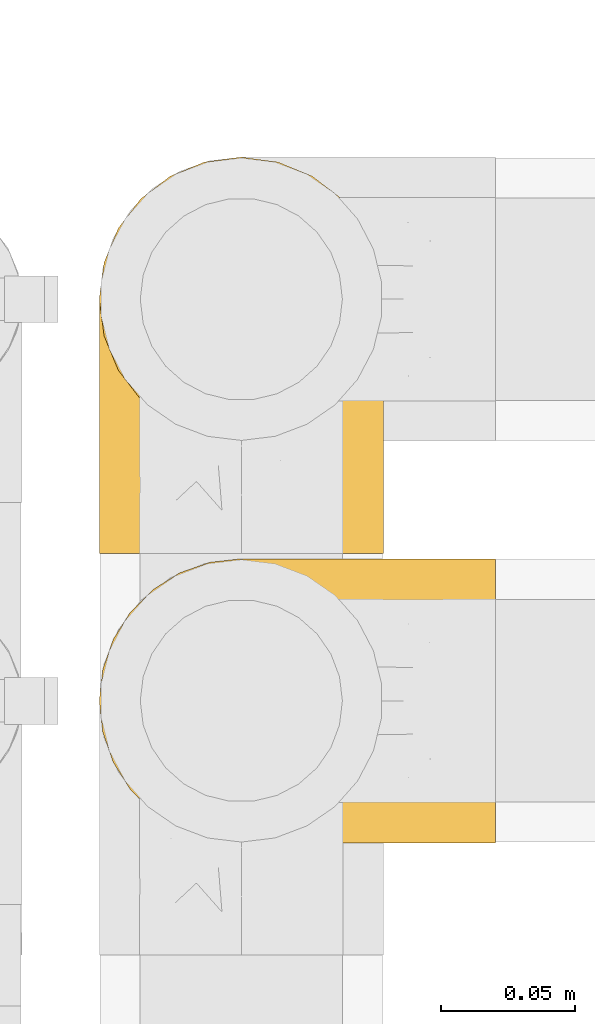
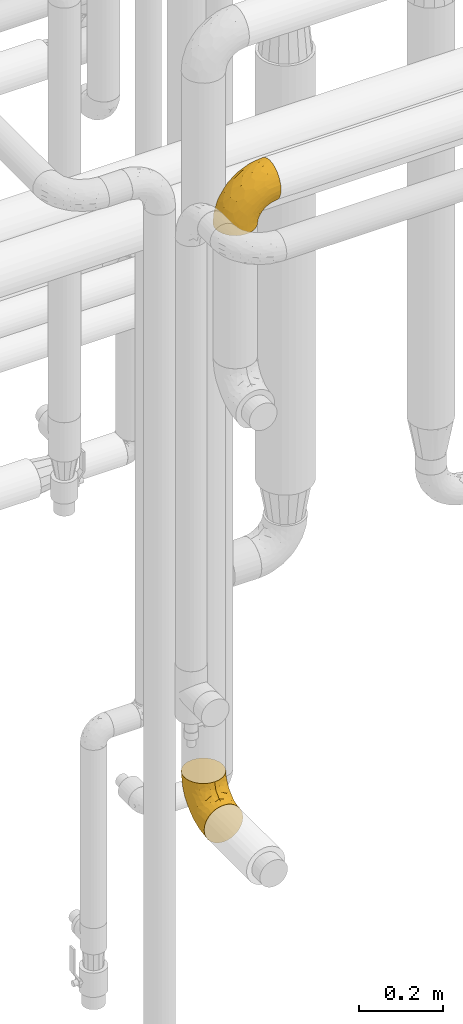
# One storey, part 439 of 827: 2 coverings.
"""IFC2X3 building model written with IfcOpenShell, lengths in millimetres."""

import ifcopenshell
import ifcopenshell.guid

model = None  # the IFC model being written
_history = None  # IfcOwnerHistory: only IFC2X3 demands one
_inside = {}  # id of a spatial element -> (the spatial element, [elements in it])
_under = {}  # id of a project, library or spatial element -> (it, [spatial elements below it])
_declared = {}  # id of a project -> (the project, [libraries it declares])
_typed = {}  # id of a type object -> (the type object, [elements of that type])
_made_of = {}  # id of a material, layer set ... -> (it, [elements and type objects made of it])


def new_model(schema):
    """Start an empty IFC model of exactly this schema.

    Asked for "IFC4X3", IfcOpenShell would pick the latest addendum, in which some entities
    have other attributes; the version numbers below select the first issue.
    IFC2X3 requires an IfcOwnerHistory on every rooted entity: one is made here for all.
    """
    global model, _history
    if schema == "IFC4X3":
        model = ifcopenshell.file(schema_version=(4, 3, 0, 0))
    else:
        model = ifcopenshell.file(schema=schema)
    _inside.clear()
    _under.clear()
    _declared.clear()
    _typed.clear()
    _made_of.clear()
    _history = None
    if model.schema == "IFC2X3":
        org = make("IfcOrganization", Name="unknown")
        user = make(
            "IfcPersonAndOrganization",
            ThePerson=make("IfcPerson", FamilyName="unknown"),
            TheOrganization=org,
        )
        app = make(
            "IfcApplication",
            ApplicationDeveloper=org,
            Version="unknown",
            ApplicationFullName="unknown",
            ApplicationIdentifier="unknown",
        )
        _history = make(
            "IfcOwnerHistory",
            OwningUser=user,
            OwningApplication=app,
            ChangeAction="ADDED",
            CreationDate=0,
        )
    return model


def make(cls, **values):
    """One entity of the class cls with the attributes given. An attribute that is None is left unset."""
    return model.create_entity(
        cls, **{name: value for name, value in values.items() if value is not None}
    )


def entity(cls, *values):
    """Any entity or typed value of the class cls, its attributes in the order of the schema. None: left unset."""
    e = model.create_entity(cls)
    for i, value in enumerate(values):
        if value is not None:
            e[i] = value
    return e


def rooted(cls, **values):
    """An entity with a GlobalId (a new one), such as an element, a storey or a relation."""
    return make(cls, GlobalId=ifcopenshell.guid.new(), OwnerHistory=_history, **values)


def si_unit(unit_type, name, prefix=None):
    """IfcSIUnit, for example si_unit("LENGTHUNIT", "METRE", prefix="MILLI")."""
    return make("IfcSIUnit", UnitType=unit_type, Prefix=prefix, Name=name)


def converted_unit(unit_type, name, factor, base, dimensions=None, offset=None):
    """IfcConversionBasedUnit, such as the inch: factor (a typed value) times the base unit."""
    return make(
        "IfcConversionBasedUnit"
        if offset is None
        else "IfcConversionBasedUnitWithOffset",
        ConversionOffset=offset,
        Dimensions=None
        if dimensions is None
        else entity("IfcDimensionalExponents", *dimensions),
        UnitType=unit_type,
        Name=name,
        ConversionFactor=make(
            "IfcMeasureWithUnit", ValueComponent=factor, UnitComponent=base
        ),
    )


def derived_unit(unit_type, elements):
    """IfcDerivedUnit: a product of units, each with its exponent."""
    return make(
        "IfcDerivedUnit",
        Elements=[
            make("IfcDerivedUnitElement", Unit=unit, Exponent=power)
            for unit, power in elements
        ],
        UnitType=unit_type,
    )


def assignment(units):
    """IfcUnitAssignment: the units of a project."""
    return None if units is None else make("IfcUnitAssignment", Units=units)


def point(xyz):
    """IfcCartesianPoint."""
    return None if xyz is None else make("IfcCartesianPoint", Coordinates=xyz)


def direction(xyz):
    """IfcDirection."""
    return None if xyz is None else make("IfcDirection", DirectionRatios=xyz)


def frame(location, z_axis=None, x_axis=None):
    """IfcAxis2Placement3D, a coordinate frame: its origin and axes. An axis left out is left unset."""
    return make(
        "IfcAxis2Placement3D",
        Location=point(location),
        Axis=direction(z_axis),
        RefDirection=direction(x_axis),
    )


def origin():
    """The frame at (0, 0, 0) with its axes left unset."""
    return frame((0.0, 0.0, 0.0))


def place(relative_to, where):
    """IfcLocalPlacement: puts the frame where relative to a parent placement (None: the world)."""
    return make(
        "IfcLocalPlacement", PlacementRelTo=relative_to, RelativePlacement=where
    )


def context(
    kind, dimensions, precision=None, world=None, true_north=None, identifier=None
):
    """IfcGeometricRepresentationContext, for example the 3D "Model" context."""
    return make(
        "IfcGeometricRepresentationContext",
        ContextIdentifier=identifier,
        ContextType=kind,
        CoordinateSpaceDimension=dimensions,
        Precision=precision,
        WorldCoordinateSystem=world,
        TrueNorth=true_north,
    )


def subcontext(parent, identifier, kind, view, scale=None):
    """IfcGeometricRepresentationSubContext, for example "Body" below "Model"."""
    return make(
        "IfcGeometricRepresentationSubContext",
        ContextIdentifier=identifier,
        ContextType=kind,
        ParentContext=parent,
        TargetScale=scale,
        TargetView=view,
    )


def project(units=None, contexts=None):
    """IfcProject with its units and contexts."""
    return rooted(
        "IfcProject",
        Name="project",
        RepresentationContexts=contexts,
        UnitsInContext=assignment(units),
    )


def spatial(cls, under=None, at=None, **own):
    """A site, building, storey or space (cls), placed at a placement, below another one or the project."""
    s = rooted(cls, ObjectPlacement=at, **own)
    if under is not None:
        _under.setdefault(under.id(), (under, []))[1].append(s)
    return s


def faces_of(points, faces, orient=None, outer=None):
    """IfcFace entities. A face is a list of loops; a loop is a list of indices into points, from 0.

    orient and outer hold one flag for each loop. By default every Orientation is true, the
    first loop of a face is its IfcFaceOuterBound and the others are IfcFaceBound.
    """
    made = []
    for i, loops in enumerate(faces):
        bounds = []
        for j, loop in enumerate(loops):
            is_outer = j == 0 if outer is None else outer[i][j]
            bounds.append(
                make(
                    "IfcFaceOuterBound" if is_outer else "IfcFaceBound",
                    Bound=make("IfcPolyLoop", Polygon=[points[k] for k in loop]),
                    Orientation=True if orient is None else orient[i][j],
                )
            )
        made.append(make("IfcFace", Bounds=bounds))
    return made


def faceted_brep(points, faces, orient=None, outer=None, voids=None):
    """IfcFacetedBrep: a solid bounded by flat faces; with voids (closed shells), ...WithVoids."""
    shared = [point(p) for p in points]
    hull = make("IfcClosedShell", CfsFaces=faces_of(shared, faces, orient, outer))
    if voids is None:
        return make("IfcFacetedBrep", Outer=hull)
    return make(
        "IfcFacetedBrepWithVoids",
        Outer=hull,
        Voids=[
            make(cls, CfsFaces=faces_of(shared, fs, o, b)) for cls, fs, o, b in voids
        ],
    )


def shape(context_of_items, identifier, shape_type, items):
    """IfcShapeRepresentation: the items that make up one representation, for example the "Body"."""
    return make(
        "IfcShapeRepresentation",
        ContextOfItems=context_of_items,
        RepresentationIdentifier=identifier,
        RepresentationType=shape_type,
        Items=items,
    )


def made_of(thing, what):
    """Note that an element or type object is made of a material, layer set ...; save() writes the relation."""
    if what is not None:
        _made_of.setdefault(what.id(), (what, []))[1].append(thing)
    return thing


def element(
    cls,
    number,
    at=None,
    inside=None,
    cuts=None,
    type_object=None,
    material=None,
    context=None,
    identifier="Body",
    shape_type=None,
    held_by="IfcProductDefinitionShape",
    body=None,
    shapes=None,
    **own,
):
    """One element of the class cls, such as IfcWall. Its Tag is "e" and its number.

    at: its placement. inside: the storey or other place that contains it. cuts: it is an
    opening in that element (IfcRelVoidsElement). A single representation is given by context,
    identifier, shape_type and body (its items); several are given by shapes. held_by: the class
    of the entity that holds the representations. save() writes the other relations.
    """
    e = rooted(cls, Tag="e%d" % number, ObjectPlacement=at, **own)
    if body is not None:
        shapes = [shape(context, identifier, shape_type, body)]
    if shapes is not None:
        e.Representation = make(held_by, Representations=shapes)
    if inside is not None:
        _inside.setdefault(inside.id(), (inside, []))[1].append(e)
    if cuts is not None:
        rooted(
            "IfcRelVoidsElement", RelatingBuildingElement=cuts, RelatedOpeningElement=e
        )
    if type_object is not None:
        _typed.setdefault(type_object.id(), (type_object, []))[1].append(e)
    return made_of(e, material)


def aggregate(whole, parts):
    """IfcRelAggregates: a whole, such as a stair, and the parts it consists of."""
    return rooted("IfcRelAggregates", RelatingObject=whole, RelatedObjects=parts)


def save(model, path):
    """Write the relations noted so far, then the file.

    IfcRelAggregates (storeys below a building ...), IfcRelContainedInSpatialStructure (elements
    in a storey), IfcRelDefinesByType, IfcRelAssociatesMaterial and IfcRelDeclares: one each for
    every whole, place, type object, material and project.
    """
    for whole, parts in _under.values():
        aggregate(whole, parts)
    for where, things in _inside.values():
        rooted(
            "IfcRelContainedInSpatialStructure",
            RelatedElements=things,
            RelatingStructure=where,
        )
    for kind, things in _typed.values():
        rooted("IfcRelDefinesByType", RelatedObjects=things, RelatingType=kind)
    for what, things in _made_of.values():
        rooted("IfcRelAssociatesMaterial", RelatedObjects=things, RelatingMaterial=what)
    for by, libraries in _declared.values():
        rooted("IfcRelDeclares", RelatingContext=by, RelatedDefinitions=libraries)
    model.write(path)


model = new_model("IFC2X3")

# Units and contexts
model_context = context("Model", 3, precision=0.01, world=origin(), true_north=direction((6.12303176911189e-17, 1.0)))
body_context = subcontext(model_context, "Body", "Model", "MODEL_VIEW")
ifc_project = project(units=[si_unit("LENGTHUNIT", "METRE", prefix="MILLI"), si_unit("AREAUNIT", "SQUARE_METRE"), si_unit("VOLUMEUNIT", "CUBIC_METRE"), converted_unit("PLANEANGLEUNIT", "DEGREE", entity("IfcRatioMeasure", 0.0174532925199433), si_unit("PLANEANGLEUNIT", "RADIAN"), dimensions=[0, 0, 0, 0, 0, 0, 0]), si_unit("MASSUNIT", "GRAM", prefix="KILO"), derived_unit("MASSDENSITYUNIT", [(si_unit("MASSUNIT", "GRAM", prefix="KILO"), 1), (si_unit("LENGTHUNIT", "METRE"), -3)]), derived_unit("MOMENTOFINERTIAUNIT", [(si_unit("LENGTHUNIT", "METRE"), 4)]), si_unit("TIMEUNIT", "SECOND"), si_unit("FREQUENCYUNIT", "HERTZ"), si_unit("THERMODYNAMICTEMPERATUREUNIT", "DEGREE_CELSIUS"), derived_unit("THERMALTRANSMITTANCEUNIT", [(si_unit("MASSUNIT", "GRAM", prefix="KILO"), 1), (si_unit("THERMODYNAMICTEMPERATUREUNIT", "KELVIN"), -1), (si_unit("TIMEUNIT", "SECOND"), -3)]), derived_unit("VOLUMETRICFLOWRATEUNIT", [(si_unit("LENGTHUNIT", "METRE"), 3), (si_unit("TIMEUNIT", "SECOND"), -1)]), derived_unit("MASSFLOWRATEUNIT", [(si_unit("MASSUNIT", "GRAM", prefix="KILO"), 1), (si_unit("TIMEUNIT", "SECOND"), -1)]), derived_unit("ROTATIONALFREQUENCYUNIT", [(si_unit("TIMEUNIT", "SECOND"), -1)]), si_unit("ELECTRICCURRENTUNIT", "AMPERE"), si_unit("ELECTRICVOLTAGEUNIT", "VOLT"), si_unit("POWERUNIT", "WATT"), si_unit("FORCEUNIT", "NEWTON", prefix="KILO"), si_unit("ILLUMINANCEUNIT", "LUX"), si_unit("LUMINOUSFLUXUNIT", "LUMEN"), si_unit("LUMINOUSINTENSITYUNIT", "CANDELA"), derived_unit("USERDEFINED", [(si_unit("MASSUNIT", "GRAM", prefix="KILO"), -1), (si_unit("LENGTHUNIT", "METRE"), -2), (si_unit("TIMEUNIT", "SECOND"), 3), (si_unit("LUMINOUSFLUXUNIT", "LUMEN"), 1)]), derived_unit("LINEARVELOCITYUNIT", [(si_unit("LENGTHUNIT", "METRE"), 1), (si_unit("TIMEUNIT", "SECOND"), -1)]), si_unit("PRESSUREUNIT", "PASCAL"), derived_unit("USERDEFINED", [(si_unit("LENGTHUNIT", "METRE"), -2), (si_unit("MASSUNIT", "GRAM", prefix="KILO"), 1), (si_unit("TIMEUNIT", "SECOND"), -2)]), derived_unit("LINEARFORCEUNIT", [(si_unit("MASSUNIT", "GRAM", prefix="KILO"), 1), (si_unit("LENGTHUNIT", "METRE"), 1), (si_unit("TIMEUNIT", "SECOND"), -2), (si_unit("LENGTHUNIT", "METRE"), -1)]), derived_unit("PLANARFORCEUNIT", [(si_unit("MASSUNIT", "GRAM", prefix="KILO"), 1), (si_unit("LENGTHUNIT", "METRE"), 1), (si_unit("TIMEUNIT", "SECOND"), -2), (si_unit("LENGTHUNIT", "METRE"), -2)])], contexts=[model_context])

# Site, building, storey
site_placement = place(None, origin())
site = spatial("IfcSite", under=ifc_project, at=site_placement, CompositionType="ELEMENT")
building_placement = place(site_placement, origin())
building = spatial("IfcBuilding", under=site, at=building_placement, CompositionType="ELEMENT")
storey_placement = place(building_placement, frame((0.0, 0.0, 28200.0)))
storey = spatial("IfcBuildingStorey", under=building, at=storey_placement, Name="08", CompositionType="ELEMENT", Elevation=28200.0)

# Coverings
covering_1_placement = place(storey_placement, frame((55701.2, 15549.61, 1130.35)))
element("IfcCovering", 1, at=covering_1_placement, inside=storey, Name=":ADSK_", ObjectType=":ADSK_", PredefinedType="INSULATION", context=body_context, shape_type="Brep", body=[
    faceted_brep([(42.85, 1.6, 2.92), (54.65, 1.6, 1.6), (66.46, 1.6, 2.93), (77.67, 1.6, 6.85), (87.73, 1.6, 13.18), (96.13, 1.6, 21.58), (102.45, 1.6, 31.64), (106.37, 1.6, 42.85), (107.7, 1.6, 54.65), (106.36, 1.6, 66.46), (102.44, 1.6, 77.67), (96.11, 1.6, 87.73), (87.71, 1.6, 96.13), (77.65, 1.6, 102.45), (66.44, 1.6, 106.37), (54.65, 1.6, 107.7), (42.84, 1.6, 106.36), (31.62, 1.6, 102.44), (21.56, 1.6, 96.11), (13.16, 1.6, 87.71), (6.84, 1.6, 77.65), (2.92, 1.6, 66.44), (1.6, 1.6, 54.65), (2.93, 1.6, 42.84), (6.85, 1.6, 31.62), (13.18, 1.6, 21.56), (21.58, 1.6, 13.16), (31.64, 1.6, 6.84), (68.38, 45.35, 149.65), (81.17, 50.65, 149.65), (92.16, 59.08, 149.65), (100.59, 70.07, 149.65), (105.89, 82.86, 149.65), (107.7, 96.6, 149.65), (105.89, 110.33, 149.65), (100.59, 123.12, 149.65), (92.16, 134.11, 149.65), (81.17, 142.54, 149.65), (68.38, 147.84, 149.65), (54.65, 149.65, 149.65), (40.91, 147.84, 149.65), (28.12, 142.54, 149.65), (17.13, 134.11, 149.65), (8.7, 123.12, 149.65), (3.4, 110.33, 149.65), (1.6, 96.6, 149.65), (3.4, 82.86, 149.65), (8.7, 70.07, 149.65), (17.13, 59.08, 149.65), (28.12, 50.65, 149.65), (40.91, 45.35, 149.65), (54.65, 43.55, 149.65), (23.76, 137.19, 123.27), (35.87, 141.79, 114.15), (25.52, 128.89, 92.97), (45.07, 146.54, 124.11), (54.65, 144.6, 111.33), (12.57, 69.77, 42.13), (15.93, 94.41, 56.83), (24.82, 87.22, 40.31), (37.92, 117.2, 61.55), (54.65, 129.81, 75.62), (54.65, 106.28, 44.96), (5.82, 101.45, 91.12), (8.38, 115.81, 109.83), (10.19, 109.14, 88.02), (3.86, 107.65, 119.19), (2.5, 93.36, 99.11), (19.48, 59.44, 27.97), (29.7, 63.23, 21.92), (28.0, 35.59, 12.94), (35.28, 132.3, 88.29), (45.15, 138.41, 95.35), (14.54, 126.28, 113.84), (54.65, 39.91, 6.64), (38.55, 37.44, 8.58), (40.99, 90.35, 33.39), (43.24, 65.0, 17.23), (8.56, 85.4, 61.99), (2.51, 26.66, 47.9), (5.69, 29.88, 37.72), (1.6, 78.45, 93.81), (1.6, 85.2, 107.05), (1.6, 91.95, 120.29), (3.22, 77.98, 73.26), (18.7, 29.55, 18.58), (11.86, 41.42, 29.72), (24.78, 111.13, 64.31), (15.99, 114.67, 82.84), (1.6, 57.43, 72.79), (1.6, 67.94, 83.3), (1.6, 14.64, 56.71), (1.6, 30.95, 59.29), (2.5, 52.13, 57.88), (1.6, 44.19, 66.04), (5.82, 60.12, 49.8), (54.65, 75.62, 21.43), (1.6, 94.27, 134.97), (32.3, 24.59, 108.79), (25.01, 34.69, 110.84), (18.18, 31.15, 101.53), (3.03, 75.18, 111.84), (6.69, 67.55, 119.98), (3.21, 79.36, 123.54), (2.73, 84.32, 134.54), (3.93, 40.81, 80.57), (2.55, 29.93, 69.55), (7.7, 70.24, 134.56), (54.65, 37.93, 128.67), (54.65, 40.15, 136.98), (41.58, 42.1, 133.56), (17.93, 55.38, 131.66), (14.97, 52.17, 117.75), (22.2, 44.32, 118.23), (43.45, 19.85, 110.55), (54.65, 14.26, 111.09), (54.65, 22.57, 113.32), (40.37, 34.17, 120.2), (8.47, 54.85, 105.95), (29.46, 44.63, 127.69), (32.17, 47.52, 139.88), (3.39, 59.1, 92.14), (7.76, 44.11, 93.82), (2.57, 53.21, 82.28), (11.54, 62.86, 130.86), (6.21, 20.58, 78.78), (2.9, 15.79, 67.58), (11.19, 27.67, 90.58), (14.27, 13.49, 90.23), (22.4, 18.04, 99.39), (34.87, 12.44, 105.17), (54.65, 30.25, 120.99), (4.01, 66.71, 104.59), (16.42, 42.52, 108.24), (91.36, 55.38, 131.66), (103.07, 20.57, 78.8), (67.71, 42.11, 133.57), (107.7, 57.43, 72.79), (106.72, 53.22, 82.27), (105.35, 40.81, 80.59), (65.83, 19.85, 110.55), (76.97, 24.58, 108.79), (68.91, 34.16, 120.2), (92.85, 42.5, 108.25), (100.82, 54.93, 106.06), (94.28, 52.13, 117.78), (98.08, 27.66, 90.6), (101.51, 44.12, 93.87), (107.7, 78.45, 93.81), (107.7, 85.2, 107.05), (106.25, 75.17, 111.89), (107.7, 94.27, 134.97), (106.56, 84.32, 134.54), (107.7, 30.95, 59.29), (107.7, 44.19, 66.04), (106.74, 29.98, 69.56), (105.31, 66.78, 104.56), (102.6, 67.55, 119.98), (101.59, 70.24, 134.56), (106.08, 79.36, 123.54), (95.01, 13.48, 90.25), (86.87, 18.03, 99.4), (84.27, 34.66, 110.83), (91.11, 31.14, 101.52), (74.4, 12.43, 105.18), (107.7, 14.64, 56.71), (77.12, 47.52, 139.89), (87.06, 44.28, 118.22), (106.38, 15.8, 67.6), (97.75, 62.86, 130.86), (107.7, 67.94, 83.3), (79.83, 44.64, 127.71), (105.91, 59.12, 92.12), (107.7, 91.95, 120.29), (83.77, 128.89, 92.97), (85.53, 137.19, 123.27), (94.75, 126.28, 113.84), (100.91, 115.81, 109.83), (64.22, 146.53, 124.03), (73.42, 141.79, 114.15), (64.15, 139.45, 98.04), (106.79, 93.36, 99.11), (106.79, 26.67, 47.9), (103.61, 29.87, 37.74), (103.47, 60.12, 49.8), (93.36, 94.41, 56.83), (96.75, 69.76, 42.16), (84.48, 87.19, 40.3), (106.79, 52.13, 57.88), (106.07, 77.98, 73.26), (105.43, 107.65, 119.19), (73.44, 131.74, 86.61), (89.82, 59.44, 27.99), (90.61, 29.54, 18.59), (79.61, 63.2, 21.92), (81.34, 27.9, 11.28), (68.3, 90.35, 33.39), (71.37, 117.2, 61.55), (97.44, 41.39, 29.73), (99.1, 109.14, 88.01), (100.74, 85.46, 62.08), (70.76, 37.43, 8.58), (93.3, 114.67, 82.84), (84.5, 111.12, 64.3), (103.47, 101.45, 91.12), (68.73, 65.16, 18.05)], [[[0, 1, 2, 3, 4, 5, 6, 7, 8, 9, 10, 11, 12, 13, 14, 15, 16, 17, 18, 19, 20, 21, 22, 23, 24, 25, 26, 27]], [[28, 29, 30, 31, 32, 33, 34, 35, 36, 37, 38, 39, 40, 41, 42, 43, 44, 45, 46, 47, 48, 49, 50, 51]], [[52, 53, 54]], [[55, 39, 56]], [[57, 58, 59]], [[60, 61, 62]], [[63, 64, 65]], [[66, 63, 67]], [[68, 69, 70]], [[53, 71, 54]], [[41, 40, 53]], [[53, 72, 71]], [[73, 42, 52]], [[42, 41, 52]], [[74, 0, 75]], [[69, 76, 77]], [[43, 73, 64]], [[45, 44, 66]], [[57, 78, 58]], [[23, 79, 80]], [[67, 81, 82, 83]], [[67, 84, 81]], [[24, 23, 80]], [[25, 85, 26]], [[86, 85, 25]], [[42, 73, 43]], [[0, 27, 75]], [[25, 24, 86]], [[70, 26, 85]], [[0, 74, 1]], [[68, 85, 86]], [[66, 64, 63]], [[60, 59, 87]], [[54, 87, 88]], [[76, 60, 62]], [[84, 89, 90, 81]], [[79, 22, 91, 92]], [[77, 74, 75]], [[93, 92, 94, 89]], [[80, 86, 24]], [[40, 55, 53]], [[76, 59, 60]], [[93, 84, 95]], [[76, 62, 96]], [[55, 72, 53]], [[70, 27, 26]], [[75, 70, 69]], [[78, 84, 63]], [[93, 79, 92]], [[95, 86, 80]], [[77, 76, 96]], [[59, 69, 68]], [[57, 68, 86]], [[68, 57, 59]], [[59, 58, 87]], [[76, 69, 59]], [[88, 87, 58]], [[87, 54, 71]], [[86, 95, 57]], [[78, 57, 95]], [[84, 78, 95]], [[78, 63, 65]], [[58, 78, 65]], [[54, 88, 73]], [[84, 93, 89]], [[79, 95, 80]], [[79, 93, 95]], [[22, 79, 23]], [[66, 83, 97, 45]], [[84, 67, 63]], [[83, 66, 67]], [[64, 44, 43]], [[64, 66, 44]], [[65, 73, 88]], [[53, 52, 41]], [[73, 52, 54]], [[73, 65, 64]], [[65, 88, 58]], [[39, 55, 40]], [[72, 55, 56]], [[56, 61, 72]], [[60, 72, 61]], [[72, 60, 71]], [[87, 71, 60]], [[27, 70, 75]], [[68, 70, 85]], [[74, 77, 96]], [[69, 77, 75]], [[98, 99, 100]], [[46, 45, 97]], [[101, 102, 103]], [[103, 104, 83]], [[105, 94, 106]], [[107, 103, 102]], [[108, 109, 51, 110]], [[111, 112, 113]], [[114, 115, 116]], [[47, 104, 107]], [[110, 117, 108]], [[49, 48, 111]], [[102, 118, 112]], [[119, 120, 111]], [[50, 49, 120]], [[121, 122, 118]], [[105, 123, 89]], [[124, 48, 107]], [[20, 19, 125]], [[121, 81, 90]], [[117, 119, 99]], [[21, 20, 126]], [[22, 21, 91]], [[105, 125, 127]], [[110, 51, 50]], [[19, 128, 125]], [[16, 15, 115]], [[129, 98, 100]], [[126, 91, 21]], [[128, 129, 127]], [[122, 123, 105]], [[114, 117, 98]], [[17, 16, 130]], [[18, 128, 19]], [[129, 18, 17]], [[125, 106, 126]], [[115, 114, 16]], [[130, 129, 17]], [[114, 98, 130]], [[117, 116, 131, 108]], [[99, 119, 113]], [[122, 121, 123]], [[92, 126, 106]], [[105, 127, 122]], [[132, 121, 118]], [[114, 130, 16]], [[129, 130, 98]], [[50, 120, 110]], [[129, 128, 18]], [[125, 128, 127]], [[125, 126, 20]], [[91, 126, 92]], [[105, 89, 94]], [[105, 106, 125]], [[94, 92, 106]], [[100, 122, 127]], [[118, 122, 133]], [[112, 118, 133]], [[132, 118, 102]], [[132, 102, 101]], [[81, 121, 132]], [[82, 103, 83]], [[132, 101, 81]], [[104, 47, 46]], [[124, 107, 102]], [[48, 47, 107]], [[113, 112, 133]], [[112, 111, 124]], [[99, 113, 133]], [[111, 113, 119]], [[99, 133, 100]], [[117, 99, 98]], [[122, 100, 133]], [[127, 129, 100]], [[103, 82, 101]], [[81, 101, 82]], [[112, 124, 102]], [[48, 124, 111]], [[104, 103, 107]], [[46, 97, 104]], [[111, 120, 49]], [[83, 104, 97]], [[110, 120, 119]], [[117, 110, 119]], [[116, 117, 114]], [[89, 123, 90]], [[90, 123, 121]], [[30, 29, 134]], [[11, 10, 135]], [[51, 109, 108, 136]], [[137, 138, 139]], [[140, 141, 142]], [[143, 144, 145]], [[146, 139, 147]], [[148, 149, 150]], [[151, 32, 152]], [[153, 154, 155]], [[156, 150, 157]], [[158, 157, 159]], [[108, 142, 136]], [[31, 158, 152]], [[160, 161, 12]], [[162, 163, 143]], [[140, 142, 116]], [[142, 141, 162]], [[14, 164, 140]], [[14, 140, 115]], [[9, 8, 165]], [[160, 12, 11]], [[141, 164, 161]], [[13, 12, 161]], [[14, 115, 15]], [[28, 166, 29]], [[135, 139, 146]], [[141, 163, 162]], [[135, 146, 160]], [[143, 167, 162]], [[29, 166, 134]], [[116, 142, 108, 131]], [[165, 153, 168]], [[10, 9, 168]], [[168, 135, 10]], [[138, 147, 139]], [[158, 169, 157]], [[14, 13, 164]], [[116, 115, 140]], [[145, 167, 143]], [[135, 160, 11]], [[168, 153, 155]], [[138, 137, 170]], [[157, 144, 156]], [[147, 144, 143]], [[161, 164, 13]], [[140, 164, 141]], [[142, 171, 136]], [[136, 171, 166]], [[161, 160, 146]], [[165, 168, 9]], [[155, 139, 135]], [[139, 154, 137]], [[168, 155, 135]], [[139, 155, 154]], [[144, 147, 172]], [[163, 147, 143]], [[156, 144, 172]], [[157, 169, 145]], [[172, 148, 156]], [[173, 159, 149]], [[159, 157, 150]], [[152, 159, 173]], [[159, 152, 158]], [[31, 30, 158]], [[169, 30, 134]], [[157, 145, 144]], [[167, 134, 171]], [[134, 167, 145]], [[171, 142, 162]], [[162, 167, 171]], [[163, 141, 161]], [[161, 146, 163]], [[147, 163, 146]], [[148, 150, 156]], [[149, 159, 150]], [[30, 169, 158]], [[145, 169, 134]], [[151, 33, 32]], [[31, 152, 32]], [[152, 173, 151]], [[28, 51, 136]], [[134, 166, 171]], [[28, 136, 166]], [[138, 170, 172]], [[147, 138, 172]], [[148, 172, 170]], [[174, 175, 176]], [[35, 34, 177]], [[178, 179, 180]], [[181, 173, 149, 148]], [[182, 183, 184]], [[185, 186, 187]], [[188, 189, 137]], [[190, 33, 151, 173]], [[191, 179, 174]], [[34, 190, 177]], [[39, 38, 178]], [[192, 193, 194]], [[4, 3, 195]], [[175, 179, 37]], [[38, 37, 179]], [[35, 176, 36]], [[196, 62, 197]], [[181, 190, 173]], [[37, 36, 175]], [[183, 6, 198]], [[189, 148, 170, 137]], [[185, 199, 200]], [[3, 2, 201]], [[202, 185, 203]], [[8, 7, 182]], [[200, 184, 186]], [[183, 7, 6]], [[181, 189, 204]], [[200, 189, 184]], [[5, 198, 6]], [[187, 203, 185]], [[195, 3, 201]], [[205, 196, 194]], [[62, 61, 197]], [[186, 198, 192]], [[180, 179, 191]], [[2, 1, 74]], [[198, 193, 192]], [[193, 5, 4]], [[194, 193, 195]], [[2, 74, 201]], [[5, 193, 198]], [[205, 74, 96]], [[188, 137, 154, 153]], [[62, 196, 96]], [[56, 178, 180]], [[198, 184, 183]], [[184, 188, 182]], [[203, 197, 191]], [[205, 194, 201]], [[187, 192, 194]], [[192, 187, 186]], [[194, 196, 187]], [[197, 187, 196]], [[197, 203, 187]], [[202, 174, 176]], [[200, 186, 185]], [[184, 198, 186]], [[199, 185, 202]], [[189, 200, 204]], [[174, 202, 203]], [[176, 177, 199]], [[189, 181, 148]], [[190, 181, 204]], [[190, 204, 177]], [[190, 34, 33]], [[188, 153, 182]], [[189, 188, 184]], [[182, 153, 165, 8]], [[183, 182, 7]], [[199, 177, 204]], [[35, 177, 176]], [[176, 175, 36]], [[179, 175, 174]], [[200, 199, 204]], [[176, 199, 202]], [[203, 191, 174]], [[180, 197, 61]], [[197, 180, 191]], [[61, 56, 180]], [[39, 178, 56]], [[38, 179, 178]], [[194, 195, 201]], [[4, 195, 193]], [[74, 205, 201]], [[96, 196, 205]]]),
])
covering_2_placement = place(storey_placement, frame((55701.2, 15441.56, 2953.4)))
element("IfcCovering", 2, at=covering_2_placement, inside=storey, Name=":ADSK_", ObjectType=":ADSK_", PredefinedType="INSULATION", context=body_context, shape_type="Brep", body=[
    faceted_brep([(2.92, 42.85, 1.6), (1.6, 54.65, 1.6), (2.93, 66.46, 1.6), (6.85, 77.67, 1.6), (13.18, 87.73, 1.6), (21.58, 96.13, 1.6), (31.64, 102.45, 1.6), (42.85, 106.37, 1.6), (54.65, 107.7, 1.6), (66.46, 106.36, 1.6), (77.67, 102.44, 1.6), (87.73, 96.11, 1.6), (96.13, 87.71, 1.6), (102.45, 77.65, 1.6), (106.37, 66.44, 1.6), (107.7, 54.65, 1.6), (106.36, 42.84, 1.6), (102.44, 31.62, 1.6), (96.11, 21.56, 1.6), (87.71, 13.16, 1.6), (77.65, 6.84, 1.6), (66.44, 2.92, 1.6), (54.65, 1.6, 1.6), (42.84, 2.93, 1.6), (31.62, 6.85, 1.6), (21.56, 13.18, 1.6), (13.16, 21.58, 1.6), (6.84, 31.64, 1.6), (149.65, 68.38, 45.35), (149.65, 81.17, 50.65), (149.65, 92.16, 59.08), (149.65, 100.59, 70.07), (149.65, 105.89, 82.86), (149.65, 107.7, 96.6), (149.65, 105.89, 110.33), (149.65, 100.59, 123.12), (149.65, 92.16, 134.11), (149.65, 81.17, 142.54), (149.65, 68.38, 147.84), (149.65, 54.65, 149.65), (149.65, 40.91, 147.84), (149.65, 28.12, 142.54), (149.65, 17.13, 134.11), (149.65, 8.7, 123.12), (149.65, 3.4, 110.33), (149.65, 1.6, 96.6), (149.65, 3.4, 82.86), (149.65, 8.7, 70.07), (149.65, 17.13, 59.08), (149.65, 28.12, 50.65), (149.65, 40.91, 45.35), (149.65, 54.65, 43.55), (123.27, 23.76, 137.19), (114.15, 35.87, 141.79), (92.97, 25.52, 128.89), (124.11, 45.07, 146.54), (111.33, 54.65, 144.6), (42.13, 12.57, 69.77), (56.83, 15.93, 94.41), (40.31, 24.82, 87.22), (61.55, 37.92, 117.2), (75.62, 54.65, 129.81), (44.96, 54.65, 106.28), (91.12, 5.82, 101.45), (109.83, 8.38, 115.81), (88.02, 10.19, 109.14), (119.19, 3.86, 107.65), (99.11, 2.5, 93.36), (27.97, 19.48, 59.44), (21.92, 29.7, 63.23), (12.94, 28.0, 35.59), (88.29, 35.28, 132.3), (95.35, 45.15, 138.41), (113.84, 14.54, 126.28), (6.64, 54.65, 39.91), (8.58, 38.55, 37.44), (33.39, 40.99, 90.35), (17.23, 43.24, 65.0), (61.99, 8.56, 85.4), (47.9, 2.51, 26.66), (37.72, 5.69, 29.88), (93.81, 1.6, 78.45), (107.05, 1.6, 85.2), (120.29, 1.6, 91.95), (73.26, 3.22, 77.98), (18.58, 18.7, 29.55), (29.72, 11.86, 41.42), (64.31, 24.78, 111.13), (82.84, 15.99, 114.67), (72.79, 1.6, 57.43), (83.3, 1.6, 67.94), (56.71, 1.6, 14.64), (59.29, 1.6, 30.95), (57.88, 2.5, 52.13), (66.04, 1.6, 44.19), (49.8, 5.82, 60.12), (21.43, 54.65, 75.62), (134.97, 1.6, 94.27), (108.79, 32.3, 24.59), (110.84, 25.01, 34.69), (101.53, 18.18, 31.15), (111.84, 3.03, 75.18), (119.98, 6.69, 67.55), (123.54, 3.21, 79.36), (134.54, 2.73, 84.32), (80.57, 3.93, 40.81), (69.55, 2.55, 29.93), (134.56, 7.7, 70.24), (128.67, 54.65, 37.93), (136.98, 54.65, 40.15), (133.56, 41.58, 42.1), (131.66, 17.93, 55.38), (117.75, 14.97, 52.17), (118.23, 22.2, 44.32), (110.55, 43.45, 19.85), (111.09, 54.65, 14.26), (113.32, 54.65, 22.57), (120.2, 40.37, 34.17), (105.95, 8.47, 54.85), (127.69, 29.46, 44.63), (139.88, 32.17, 47.52), (92.14, 3.39, 59.1), (93.82, 7.76, 44.11), (82.28, 2.57, 53.21), (130.86, 11.54, 62.86), (78.78, 6.21, 20.58), (67.58, 2.9, 15.79), (90.58, 11.19, 27.67), (90.23, 14.27, 13.49), (99.39, 22.4, 18.04), (105.17, 34.87, 12.44), (120.99, 54.65, 30.25), (104.59, 4.01, 66.71), (108.24, 16.42, 42.52), (131.66, 91.36, 55.38), (78.8, 103.07, 20.57), (133.57, 67.71, 42.11), (72.79, 107.7, 57.43), (82.27, 106.72, 53.22), (80.59, 105.35, 40.81), (110.55, 65.83, 19.85), (108.79, 76.97, 24.58), (120.2, 68.91, 34.16), (108.25, 92.85, 42.5), (106.06, 100.82, 54.93), (117.78, 94.28, 52.13), (90.6, 98.08, 27.66), (93.87, 101.51, 44.12), (93.81, 107.7, 78.45), (107.05, 107.7, 85.2), (111.89, 106.25, 75.17), (134.97, 107.7, 94.27), (134.54, 106.56, 84.32), (59.29, 107.7, 30.95), (66.04, 107.7, 44.19), (69.56, 106.74, 29.98), (104.56, 105.31, 66.78), (119.98, 102.6, 67.55), (134.56, 101.59, 70.24), (123.54, 106.08, 79.36), (90.25, 95.01, 13.48), (99.4, 86.87, 18.03), (110.83, 84.27, 34.66), (101.52, 91.11, 31.14), (105.18, 74.4, 12.43), (56.71, 107.7, 14.64), (139.89, 77.12, 47.52), (118.22, 87.06, 44.28), (67.6, 106.38, 15.8), (130.86, 97.75, 62.86), (83.3, 107.7, 67.94), (127.71, 79.83, 44.64), (92.12, 105.91, 59.12), (120.29, 107.7, 91.95), (92.97, 83.77, 128.89), (123.27, 85.53, 137.19), (113.84, 94.75, 126.28), (109.83, 100.91, 115.81), (124.03, 64.22, 146.53), (114.15, 73.42, 141.79), (98.04, 64.15, 139.45), (99.11, 106.79, 93.36), (47.9, 106.79, 26.67), (37.74, 103.61, 29.87), (49.8, 103.47, 60.12), (56.83, 93.36, 94.41), (42.16, 96.75, 69.76), (40.3, 84.48, 87.19), (57.88, 106.79, 52.13), (73.26, 106.07, 77.98), (119.19, 105.43, 107.65), (86.61, 73.44, 131.74), (27.99, 89.82, 59.44), (18.59, 90.61, 29.54), (21.92, 79.61, 63.2), (11.28, 81.34, 27.9), (33.39, 68.3, 90.35), (61.55, 71.37, 117.2), (29.73, 97.44, 41.39), (88.01, 99.1, 109.14), (62.08, 100.74, 85.46), (8.58, 70.76, 37.43), (82.84, 93.3, 114.67), (64.3, 84.5, 111.12), (91.12, 103.47, 101.45), (18.05, 68.73, 65.16)], [[[0, 1, 2, 3, 4, 5, 6, 7, 8, 9, 10, 11, 12, 13, 14, 15, 16, 17, 18, 19, 20, 21, 22, 23, 24, 25, 26, 27]], [[28, 29, 30, 31, 32, 33, 34, 35, 36, 37, 38, 39, 40, 41, 42, 43, 44, 45, 46, 47, 48, 49, 50, 51]], [[52, 53, 54]], [[55, 39, 56]], [[57, 58, 59]], [[60, 61, 62]], [[63, 64, 65]], [[66, 63, 67]], [[68, 69, 70]], [[53, 71, 54]], [[41, 40, 53]], [[53, 72, 71]], [[73, 42, 52]], [[42, 41, 52]], [[74, 0, 75]], [[69, 76, 77]], [[43, 73, 64]], [[45, 44, 66]], [[57, 78, 58]], [[23, 79, 80]], [[67, 81, 82, 83]], [[67, 84, 81]], [[24, 23, 80]], [[25, 85, 26]], [[86, 85, 25]], [[42, 73, 43]], [[0, 27, 75]], [[25, 24, 86]], [[70, 26, 85]], [[0, 74, 1]], [[68, 85, 86]], [[66, 64, 63]], [[60, 59, 87]], [[54, 87, 88]], [[76, 60, 62]], [[84, 89, 90, 81]], [[79, 22, 91, 92]], [[77, 74, 75]], [[93, 92, 94, 89]], [[80, 86, 24]], [[40, 55, 53]], [[76, 59, 60]], [[93, 84, 95]], [[76, 62, 96]], [[55, 72, 53]], [[70, 27, 26]], [[75, 70, 69]], [[78, 84, 63]], [[93, 79, 92]], [[95, 86, 80]], [[77, 76, 96]], [[59, 69, 68]], [[57, 68, 86]], [[68, 57, 59]], [[59, 58, 87]], [[76, 69, 59]], [[88, 87, 58]], [[87, 54, 71]], [[86, 95, 57]], [[78, 57, 95]], [[84, 78, 95]], [[78, 63, 65]], [[58, 78, 65]], [[54, 88, 73]], [[84, 93, 89]], [[79, 95, 80]], [[79, 93, 95]], [[22, 79, 23]], [[66, 83, 97, 45]], [[84, 67, 63]], [[83, 66, 67]], [[64, 44, 43]], [[64, 66, 44]], [[65, 73, 88]], [[53, 52, 41]], [[73, 52, 54]], [[73, 65, 64]], [[65, 88, 58]], [[39, 55, 40]], [[72, 55, 56]], [[56, 61, 72]], [[60, 72, 61]], [[72, 60, 71]], [[87, 71, 60]], [[27, 70, 75]], [[68, 70, 85]], [[74, 77, 96]], [[69, 77, 75]], [[98, 99, 100]], [[46, 45, 97]], [[101, 102, 103]], [[103, 104, 83]], [[105, 94, 106]], [[107, 103, 102]], [[108, 109, 51, 110]], [[111, 112, 113]], [[114, 115, 116]], [[47, 104, 107]], [[110, 117, 108]], [[49, 48, 111]], [[102, 118, 112]], [[119, 120, 111]], [[50, 49, 120]], [[121, 122, 118]], [[105, 123, 89]], [[124, 48, 107]], [[20, 19, 125]], [[121, 81, 90]], [[117, 119, 99]], [[21, 20, 126]], [[22, 21, 91]], [[105, 125, 127]], [[110, 51, 50]], [[19, 128, 125]], [[16, 15, 115]], [[129, 98, 100]], [[126, 91, 21]], [[128, 129, 127]], [[122, 123, 105]], [[114, 117, 98]], [[17, 16, 130]], [[18, 128, 19]], [[129, 18, 17]], [[125, 106, 126]], [[115, 114, 16]], [[130, 129, 17]], [[114, 98, 130]], [[117, 116, 131, 108]], [[99, 119, 113]], [[122, 121, 123]], [[92, 126, 106]], [[105, 127, 122]], [[132, 121, 118]], [[114, 130, 16]], [[129, 130, 98]], [[50, 120, 110]], [[129, 128, 18]], [[125, 128, 127]], [[125, 126, 20]], [[91, 126, 92]], [[105, 89, 94]], [[105, 106, 125]], [[94, 92, 106]], [[100, 122, 127]], [[118, 122, 133]], [[112, 118, 133]], [[132, 118, 102]], [[132, 102, 101]], [[81, 121, 132]], [[82, 103, 83]], [[132, 101, 81]], [[104, 47, 46]], [[124, 107, 102]], [[48, 47, 107]], [[113, 112, 133]], [[112, 111, 124]], [[99, 113, 133]], [[111, 113, 119]], [[99, 133, 100]], [[117, 99, 98]], [[122, 100, 133]], [[127, 129, 100]], [[103, 82, 101]], [[81, 101, 82]], [[112, 124, 102]], [[48, 124, 111]], [[104, 103, 107]], [[46, 97, 104]], [[111, 120, 49]], [[83, 104, 97]], [[110, 120, 119]], [[117, 110, 119]], [[116, 117, 114]], [[89, 123, 90]], [[90, 123, 121]], [[30, 29, 134]], [[11, 10, 135]], [[51, 109, 108, 136]], [[137, 138, 139]], [[140, 141, 142]], [[143, 144, 145]], [[146, 139, 147]], [[148, 149, 150]], [[151, 32, 152]], [[153, 154, 155]], [[156, 150, 157]], [[158, 157, 159]], [[108, 142, 136]], [[31, 158, 152]], [[160, 161, 12]], [[162, 163, 143]], [[140, 142, 116]], [[142, 141, 162]], [[14, 164, 140]], [[14, 140, 115]], [[9, 8, 165]], [[160, 12, 11]], [[141, 164, 161]], [[13, 12, 161]], [[14, 115, 15]], [[28, 166, 29]], [[135, 139, 146]], [[141, 163, 162]], [[135, 146, 160]], [[143, 167, 162]], [[29, 166, 134]], [[116, 142, 108, 131]], [[165, 153, 168]], [[10, 9, 168]], [[168, 135, 10]], [[138, 147, 139]], [[158, 169, 157]], [[14, 13, 164]], [[116, 115, 140]], [[145, 167, 143]], [[135, 160, 11]], [[168, 153, 155]], [[138, 137, 170]], [[157, 144, 156]], [[147, 144, 143]], [[161, 164, 13]], [[140, 164, 141]], [[142, 171, 136]], [[136, 171, 166]], [[161, 160, 146]], [[165, 168, 9]], [[155, 139, 135]], [[139, 154, 137]], [[168, 155, 135]], [[139, 155, 154]], [[144, 147, 172]], [[163, 147, 143]], [[156, 144, 172]], [[157, 169, 145]], [[172, 148, 156]], [[173, 159, 149]], [[159, 157, 150]], [[152, 159, 173]], [[159, 152, 158]], [[31, 30, 158]], [[169, 30, 134]], [[157, 145, 144]], [[167, 134, 171]], [[134, 167, 145]], [[171, 142, 162]], [[162, 167, 171]], [[163, 141, 161]], [[161, 146, 163]], [[147, 163, 146]], [[148, 150, 156]], [[149, 159, 150]], [[30, 169, 158]], [[145, 169, 134]], [[151, 33, 32]], [[31, 152, 32]], [[152, 173, 151]], [[28, 51, 136]], [[134, 166, 171]], [[28, 136, 166]], [[138, 170, 172]], [[147, 138, 172]], [[148, 172, 170]], [[174, 175, 176]], [[35, 34, 177]], [[178, 179, 180]], [[181, 173, 149, 148]], [[182, 183, 184]], [[185, 186, 187]], [[188, 189, 137]], [[190, 33, 151, 173]], [[191, 179, 174]], [[34, 190, 177]], [[39, 38, 178]], [[192, 193, 194]], [[4, 3, 195]], [[175, 179, 37]], [[38, 37, 179]], [[35, 176, 36]], [[196, 62, 197]], [[181, 190, 173]], [[37, 36, 175]], [[183, 6, 198]], [[189, 148, 170, 137]], [[185, 199, 200]], [[3, 2, 201]], [[202, 185, 203]], [[8, 7, 182]], [[200, 184, 186]], [[183, 7, 6]], [[181, 189, 204]], [[200, 189, 184]], [[5, 198, 6]], [[187, 203, 185]], [[195, 3, 201]], [[205, 196, 194]], [[62, 61, 197]], [[186, 198, 192]], [[180, 179, 191]], [[2, 1, 74]], [[198, 193, 192]], [[193, 5, 4]], [[194, 193, 195]], [[2, 74, 201]], [[5, 193, 198]], [[205, 74, 96]], [[188, 137, 154, 153]], [[62, 196, 96]], [[56, 178, 180]], [[198, 184, 183]], [[184, 188, 182]], [[203, 197, 191]], [[205, 194, 201]], [[187, 192, 194]], [[192, 187, 186]], [[194, 196, 187]], [[197, 187, 196]], [[197, 203, 187]], [[202, 174, 176]], [[200, 186, 185]], [[184, 198, 186]], [[199, 185, 202]], [[189, 200, 204]], [[174, 202, 203]], [[176, 177, 199]], [[189, 181, 148]], [[190, 181, 204]], [[190, 204, 177]], [[190, 34, 33]], [[188, 153, 182]], [[189, 188, 184]], [[182, 153, 165, 8]], [[183, 182, 7]], [[199, 177, 204]], [[35, 177, 176]], [[176, 175, 36]], [[179, 175, 174]], [[200, 199, 204]], [[176, 199, 202]], [[203, 191, 174]], [[180, 197, 61]], [[197, 180, 191]], [[61, 56, 180]], [[39, 178, 56]], [[38, 179, 178]], [[194, 195, 201]], [[4, 195, 193]], [[74, 205, 201]], [[96, 196, 205]]]),
])

save(model, "model.ifc")
